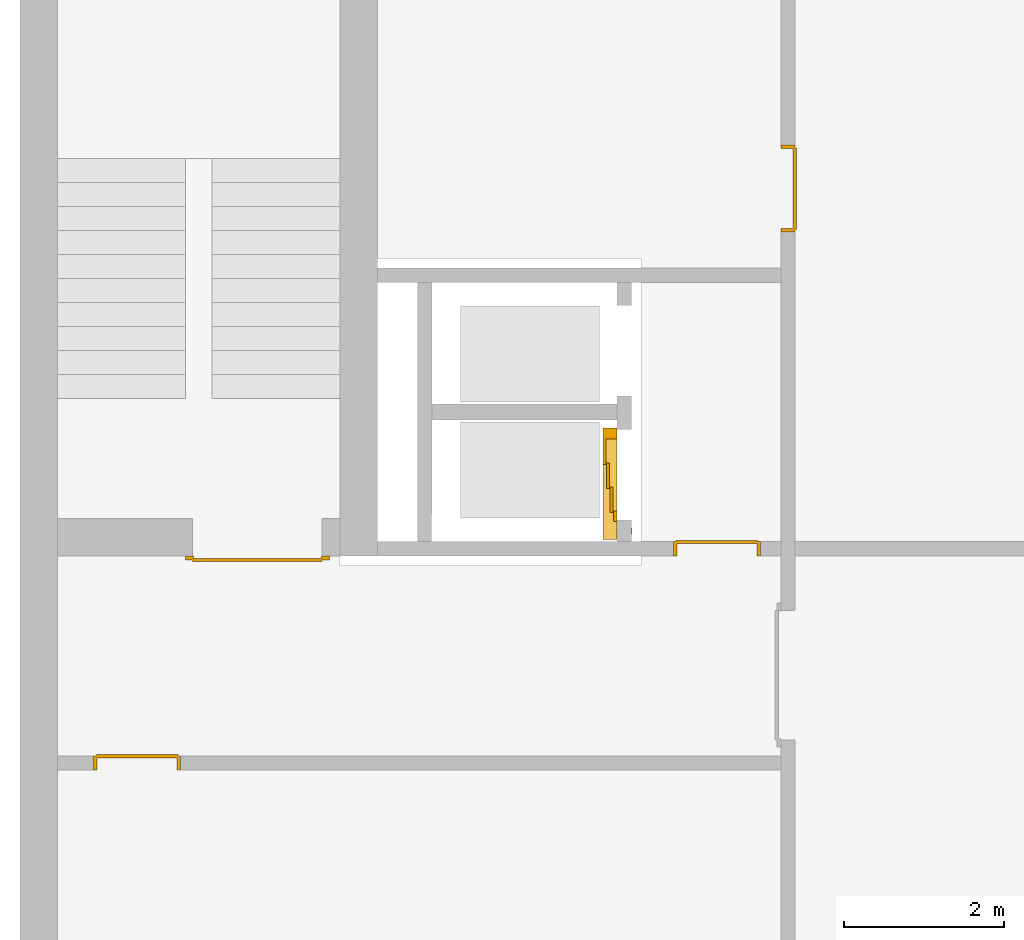
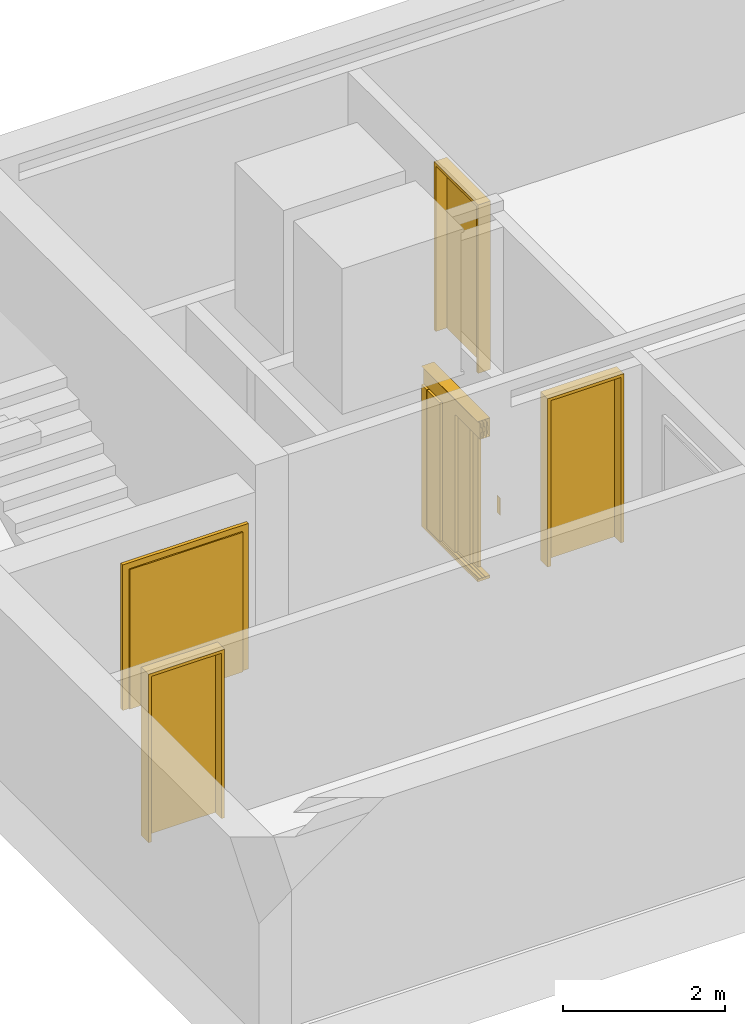
# One storey, part 4 of 5: 5 doors.
"""IFC4 building model written with IfcOpenShell, lengths in metres."""

from ifc_helpers import new_model, entity, si_unit, converted_unit, derived_unit, direction, frame, origin_with_axes, place, context, subcontext, project, spatial, polygons, source, transform, mapped, type_object, element, save


model = new_model("IFC4")

# Units and contexts
model_context = context("Model", 3, precision=1e-05, world=origin_with_axes(), true_north=direction((0.0, 1.0)))
body_context = subcontext(model_context, "Body", "Model", "MODEL_VIEW")
ifc_project = project(units=[si_unit("LENGTHUNIT", "METRE"), si_unit("AREAUNIT", "SQUARE_METRE"), si_unit("VOLUMEUNIT", "CUBIC_METRE"), converted_unit("PLANEANGLEUNIT", "DEGREE", entity("IfcPlaneAngleMeasure", 0.0174532925199433), si_unit("PLANEANGLEUNIT", "RADIAN"), dimensions=[0, 0, 0, 0, 0, 0, 0]), converted_unit("TIMEUNIT", "Year", entity("IfcTimeMeasure", 31557600.0), si_unit("TIMEUNIT", "SECOND"), dimensions=[0, 0, 1, 0, 0, 0, 0]), si_unit("MASSUNIT", "GRAM", prefix="KILO"), si_unit("THERMODYNAMICTEMPERATUREUNIT", "DEGREE_CELSIUS"), si_unit("LUMINOUSINTENSITYUNIT", "LUMEN"), si_unit("ENERGYUNIT", "JOULE", prefix="MEGA"), derived_unit("THERMALCONDUCTANCEUNIT", [(si_unit("POWERUNIT", "WATT"), 1), (si_unit("LENGTHUNIT", "METRE"), -1), (si_unit("THERMODYNAMICTEMPERATUREUNIT", "KELVIN"), -1)]), derived_unit("SPECIFICHEATCAPACITYUNIT", [(si_unit("ENERGYUNIT", "JOULE"), 1), (si_unit("MASSUNIT", "GRAM", prefix="KILO"), -1), (si_unit("THERMODYNAMICTEMPERATUREUNIT", "KELVIN"), -1)]), derived_unit("MASSDENSITYUNIT", [(si_unit("MASSUNIT", "GRAM", prefix="KILO"), 1), (si_unit("VOLUMEUNIT", "CUBIC_METRE"), -1)])], contexts=[model_context])

# Site, building, storey
site_placement = place(None, origin_with_axes())
site = spatial("IfcSite", under=ifc_project, at=site_placement, CompositionType="ELEMENT")
building_placement = place(None, origin_with_axes())
building = spatial("IfcBuilding", under=site, at=building_placement, CompositionType="ELEMENT")
storey_placement = place(None, frame((0.0, 0.0, -3.0), z_axis=(0.0, 0.0, 1.0), x_axis=(1.0, 0.0, 0.0)))
storey = spatial("IfcBuildingStorey", under=building, at=storey_placement, Name="UG", CompositionType="ELEMENT", Elevation=-3.0)

# Doors
door_type_1 = type_object("IfcDoorType", Name="27", OperationType="SINGLE_SWING_LEFT", PredefinedType="DOOR")
door_1_placement = place(None, frame((24.953, 4.55499994546755, -3.0), z_axis=(0.0, 0.0, 1.0), x_axis=(1.0, 0.0, 0.0)))
element("IfcDoor", 1, at=door_1_placement, inside=storey, type_object=door_type_1, OverallHeight=2.545, OverallWidth=1.09, context=body_context, shape_type="Tessellation", body=[
    polygons([(-0.0449999999999982, -0.179999999999999, 0.0), (-0.0449999999999982, -0.179999999999999, 2.545), (-0.0449999999999982, -0.0249999999999995, 2.545), (-0.0449999999999982, -0.0249999999999986, 0.0), (0.0, -0.179999999999999, 0.0), (0.0, -0.179999999999999, 2.5), (0.444900000000001, -0.179999999999999, 2.5), (0.4999, -0.179999999999999, 2.5), (1.0, -0.18, 2.5), (1.0, -0.179999999999999, 0.0), (1.045, -0.179999999999999, 0.0), (1.045, -0.18, 2.545), (1.045, -0.0249999999999995, 2.545), (1.045, -0.0249999999999995, 0.0), (1.0, -0.0249999999999995, 0.0), (1.0, -0.0249999999999995, 2.5), (0.4999, -0.0249999999999995, 2.5), (0.444900000000001, -0.0249999999999995, 2.5), (0.0, -0.0249999999999995, 2.5), (0.0, -0.0249999999999986, 0.0)], [[[1, 2, 3, 4]], [[1, 5, 6, 7, 8, 9, 10, 11, 12, 2]], [[2, 12, 13, 3]], [[4, 3, 13, 14, 15, 16, 17, 18, 19, 20]], [[5, 1, 4, 20]], [[6, 5, 20, 19]], [[7, 6, 19, 18]], [[8, 7, 18, 17]], [[9, 8, 17, 16]], [[10, 9, 16, 15]], [[11, 10, 15, 14]], [[12, 11, 14, 13]]], closed=True),
    polygons([(-0.0449999999999982, -0.0249999999999986, 0.0), (-0.0449999999999982, -0.0249999999999995, 2.545), (-0.0449999999999982, 0.0, 2.545), (-0.0449999999999982, 0.0, 0.0), (-0.0100000000000016, -0.0249999999999986, 0.0), (-0.0100000000000016, -0.0249999999999995, 2.51), (0.454899999999999, -0.0249999999999995, 2.51), (0.489899999999999, -0.0249999999999995, 2.51), (1.01, -0.0249999999999995, 2.51), (1.01, -0.0249999999999995, 0.0), (1.045, -0.0249999999999995, 0.0), (1.045, -0.0249999999999995, 2.545), (1.045, 0.0, 2.545), (1.045, 0.0, 0.0), (1.01, 0.0, 0.0), (1.01, 0.0, 2.51), (0.489899999999999, 0.0, 2.51), (0.454899999999999, 0.0, 2.51), (-0.0100000000000016, 0.0, 2.51), (-0.0100000000000016, 0.0, 0.0)], [[[1, 2, 3, 4]], [[1, 5, 6, 7, 8, 9, 10, 11, 12, 2]], [[2, 12, 13, 3]], [[4, 3, 13, 14, 15, 16, 17, 18, 19, 20]], [[5, 1, 4, 20]], [[6, 5, 20, 19]], [[7, 6, 19, 18]], [[8, 7, 18, 17]], [[9, 8, 17, 16]], [[10, 9, 16, 15]], [[11, 10, 15, 14]], [[12, 11, 14, 13]]], closed=True),
    polygons([(-0.0100000000000016, 0.0150000000000015, 0.0), (-0.0100000000000016, 0.0150000000000006, 2.51), (1.01, 0.0150000000000006, 2.51), (1.01, 0.0150000000000006, 0.0), (-0.0100000000000016, -0.0249999999999986, 0.0), (-0.0100000000000016, -0.0249999999999995, 2.51), (1.01, -0.0249999999999995, 2.51), (1.01, -0.0249999999999995, 0.0)], [[[1, 2, 3, 4]], [[1, 5, 6, 2]], [[2, 6, 7, 3]], [[3, 7, 8, 4]], [[4, 8, 5, 1]], [[8, 7, 6, 5]]], closed=True),
])
door_2_placement = place(None, frame((33.505, 12.1499999454676, -3.0), z_axis=(0.0, 0.0, 1.0), x_axis=(0.0, -1.0, 0.0)))
element("IfcDoor", 2, at=door_2_placement, inside=storey, type_object=door_type_1, OverallHeight=2.545, OverallWidth=1.09, context=body_context, shape_type="Tessellation", body=[
    polygons([(-0.0449999999999999, 0.0, 0.0), (-0.0449999999999999, 0.0, 2.545), (-0.0449999999999999, 0.155000000000001, 2.545), (-0.0449999999999999, 0.155000000000001, 0.0), (0.0, 0.0, 0.0), (0.0, 0.0, 2.5), (0.444900000000001, 0.0, 2.5), (0.4999, 0.0, 2.5), (1.0, 0.0, 2.5), (1.0, 0.0, 0.0), (1.045, 0.0, 0.0), (1.045, 0.0, 2.545), (1.045, 0.155000000000001, 2.545), (1.045, 0.155000000000001, 0.0), (1.0, 0.155000000000001, 0.0), (1.0, 0.155000000000001, 2.5), (0.4999, 0.155000000000001, 2.5), (0.444900000000001, 0.155000000000001, 2.5), (0.0, 0.155000000000001, 2.5), (0.0, 0.155000000000001, 0.0)], [[[1, 2, 3, 4]], [[1, 5, 6, 7, 8, 9, 10, 11, 12, 2]], [[2, 12, 13, 3]], [[4, 3, 13, 14, 15, 16, 17, 18, 19, 20]], [[5, 1, 4, 20]], [[6, 5, 20, 19]], [[7, 6, 19, 18]], [[8, 7, 18, 17]], [[9, 8, 17, 16]], [[10, 9, 16, 15]], [[11, 10, 15, 14]], [[12, 11, 14, 13]]], closed=True),
    polygons([(-0.0449999999999999, 0.155000000000001, 0.0), (-0.0449999999999999, 0.155000000000001, 2.545), (-0.0449999999999999, 0.18, 2.545), (-0.0449999999999999, 0.18, 0.0), (-0.00999999999999979, 0.155000000000001, 0.0), (-0.00999999999999979, 0.155000000000001, 2.51), (0.4549, 0.155000000000001, 2.51), (0.4899, 0.155000000000001, 2.51), (1.01, 0.155000000000001, 2.51), (1.01, 0.155000000000001, 0.0), (1.045, 0.155000000000001, 0.0), (1.045, 0.155000000000001, 2.545), (1.045, 0.18, 2.545), (1.045, 0.18, 0.0), (1.01, 0.18, 0.0), (1.01, 0.18, 2.51), (0.4899, 0.18, 2.51), (0.4549, 0.18, 2.51), (-0.00999999999999979, 0.18, 2.51), (-0.00999999999999979, 0.18, 0.0)], [[[1, 2, 3, 4]], [[1, 5, 6, 7, 8, 9, 10, 11, 12, 2]], [[2, 12, 13, 3]], [[4, 3, 13, 14, 15, 16, 17, 18, 19, 20]], [[5, 1, 4, 20]], [[6, 5, 20, 19]], [[7, 6, 19, 18]], [[8, 7, 18, 17]], [[9, 8, 17, 16]], [[10, 9, 16, 15]], [[11, 10, 15, 14]], [[12, 11, 14, 13]]], closed=True),
    polygons([(-0.00999999999999979, 0.195, 0.0), (-0.00999999999999979, 0.195, 2.51), (1.01, 0.195, 2.51), (1.01, 0.195, 0.0), (-0.00999999999999979, 0.155000000000001, 0.0), (-0.00999999999999979, 0.155000000000001, 2.51), (1.01, 0.155000000000001, 2.51), (1.01, 0.155000000000001, 0.0)], [[[1, 2, 3, 4]], [[1, 5, 6, 2]], [[2, 6, 7, 3]], [[3, 7, 8, 4]], [[4, 8, 5, 1]], [[8, 7, 6, 5]]], closed=True),
])
door_type_2 = type_object("IfcDoorType", Name="27", OperationType="SINGLE_SWING_RIGHT", PredefinedType="DOOR")
door_3_placement = place(None, frame((32.205, 7.05499994546755, -3.0), z_axis=(0.0, 0.0, 1.0), x_axis=(1.0, 0.0, 0.0)))
element("IfcDoor", 3, at=door_3_placement, inside=storey, type_object=door_type_2, OverallHeight=2.545, OverallWidth=1.09, context=body_context, shape_type="Tessellation", body=[
    polygons([(1.045, 0.0, 0.0), (1.045, 0.154999999999999, 0.0), (1.045, 0.155, 2.545), (1.045, 0.0, 2.545), (1.0, 0.0, 0.0), (1.0, 0.154999999999999, 0.0), (1.0, 0.155, 2.5), (0.555100000000003, 0.155, 2.5), (0.500100000000003, 0.155, 2.5), (0.0, 0.155, 2.5), (0.0, 0.154999999999999, 0.0), (-0.0450000000000017, 0.154999999999999, 0.0), (-0.0450000000000017, 0.155, 2.545), (-0.0450000000000017, 0.0, 2.545), (-0.0450000000000017, 0.0, 0.0), (0.0, 0.0, 0.0), (0.0, 0.0, 2.5), (0.500100000000003, 0.0, 2.5), (0.555100000000003, 0.0, 2.5), (1.0, 0.0, 2.5)], [[[1, 2, 3, 4]], [[5, 6, 2, 1]], [[2, 6, 7, 8, 9, 10, 11, 12, 13, 3]], [[4, 3, 13, 14]], [[1, 4, 14, 15, 16, 17, 18, 19, 20, 5]], [[20, 7, 6, 5]], [[19, 8, 7, 20]], [[18, 9, 8, 19]], [[17, 10, 9, 18]], [[16, 11, 10, 17]], [[15, 12, 11, 16]], [[14, 13, 12, 15]]], closed=True),
    polygons([(1.045, 0.154999999999999, 0.0), (1.045, 0.18, 0.0), (1.045, 0.18, 2.545), (1.045, 0.155, 2.545), (1.01, 0.154999999999999, 0.0), (1.01, 0.18, 0.0), (1.01, 0.18, 2.51), (0.545099999999998, 0.18, 2.51), (0.510100000000001, 0.18, 2.51), (-0.00999999999999801, 0.18, 2.51), (-0.00999999999999801, 0.18, 0.0), (-0.0450000000000017, 0.18, 0.0), (-0.0450000000000017, 0.18, 2.545), (-0.0450000000000017, 0.155, 2.545), (-0.0450000000000017, 0.154999999999999, 0.0), (-0.00999999999999801, 0.154999999999999, 0.0), (-0.00999999999999801, 0.155, 2.51), (0.510100000000001, 0.155, 2.51), (0.545099999999998, 0.155, 2.51), (1.01, 0.155, 2.51)], [[[1, 2, 3, 4]], [[5, 6, 2, 1]], [[2, 6, 7, 8, 9, 10, 11, 12, 13, 3]], [[4, 3, 13, 14]], [[1, 4, 14, 15, 16, 17, 18, 19, 20, 5]], [[20, 7, 6, 5]], [[19, 8, 7, 20]], [[18, 9, 8, 19]], [[17, 10, 9, 18]], [[16, 11, 10, 17]], [[15, 12, 11, 16]], [[14, 13, 12, 15]]], closed=True),
    polygons([(1.01, 0.194999999999999, 0.0), (-0.00999999999999801, 0.194999999999999, 0.0), (-0.00999999999999801, 0.195, 2.51), (1.01, 0.195, 2.51), (1.01, 0.154999999999999, 0.0), (-0.00999999999999801, 0.154999999999999, 0.0), (-0.00999999999999801, 0.155, 2.51), (1.01, 0.155, 2.51)], [[[1, 2, 3, 4]], [[2, 1, 5, 6]], [[3, 2, 6, 7]], [[4, 3, 7, 8]], [[1, 4, 8, 5]], [[6, 5, 8, 7]]], closed=True),
])
door_type_3 = type_object("IfcDoorType", OperationType="DOUBLE_DOOR_SINGLE_SWING", PredefinedType="DOOR")
shared_shape_1 = source(origin_with_axes(), body_context, "Body", "Tessellation", [
    polygons([(-0.9, 0.0, 0.0), (-0.9, 0.0, 2.2), (-0.9, 0.03, 2.2), (-0.9, 0.03, 0.0), (-0.8, 0.0, 0.0), (-0.8, 0.0, 2.1), (-0.1101, 0.0, 2.1), (-0.0001, 0.0, 2.1), (0.8, 0.0, 2.1), (0.8, 0.0, 0.0), (0.9, 0.0, 0.0), (0.9, 0.0, 2.2), (0.9, 0.03, 2.2), (0.9, 0.03, 0.0), (0.8, 0.03, 0.0), (0.8, 0.03, 2.1), (-0.0001, 0.03, 2.1), (-0.1101, 0.03, 2.1), (-0.8, 0.03, 2.1), (-0.8, 0.03, 0.0)], [[[1, 2, 3, 4]], [[1, 5, 6, 7, 8, 9, 10, 11, 12, 2]], [[2, 12, 13, 3]], [[4, 3, 13, 14, 15, 16, 17, 18, 19, 20]], [[5, 1, 4, 20]], [[6, 5, 20, 19]], [[7, 6, 19, 18]], [[8, 7, 18, 17]], [[9, 8, 17, 16]], [[10, 9, 16, 15]], [[11, 10, 15, 14]], [[12, 11, 14, 13]]], closed=True),
    polygons([(-0.9, 0.03, 0.0), (-0.9, 0.03, 2.2), (-0.9, 0.05, 2.2), (-0.9, 0.05, 0.0), (-0.81, 0.03, 0.0), (-0.81, 0.03, 2.11), (-0.1001, 0.03, 2.11), (-0.0101, 0.03, 2.11), (0.81, 0.03, 2.11), (0.81, 0.03, 0.0), (0.9, 0.03, 0.0), (0.9, 0.03, 2.2), (0.9, 0.05, 2.2), (0.9, 0.05, 0.0), (0.81, 0.05, 0.0), (0.81, 0.05, 2.11), (-0.0101, 0.05, 2.11), (-0.1001, 0.05, 2.11), (-0.81, 0.05, 2.11), (-0.81, 0.05, 0.0)], [[[1, 2, 3, 4]], [[1, 5, 6, 7, 8, 9, 10, 11, 12, 2]], [[2, 12, 13, 3]], [[4, 3, 13, 14, 15, 16, 17, 18, 19, 20]], [[5, 1, 4, 20]], [[6, 5, 20, 19]], [[7, 6, 19, 18]], [[8, 7, 18, 17]], [[9, 8, 17, 16]], [[10, 9, 16, 15]], [[11, 10, 15, 14]], [[12, 11, 14, 13]]], closed=True),
    polygons([(-0.81, 0.07, 0.0), (-0.81, 0.07, 2.11), (-0.000499999999999945, 0.07, 2.11), (-0.000499999999999945, 0.07, 0.0), (-0.81, 0.03, 0.0), (-0.81, 0.03, 2.11), (-0.000499999999999945, 0.03, 2.11), (-0.000499999999999945, 0.03, 0.0)], [[[1, 2, 3, 4]], [[1, 5, 6, 2]], [[2, 6, 7, 3]], [[3, 7, 8, 4]], [[4, 8, 5, 1]], [[8, 7, 6, 5]]], closed=True),
    polygons([(0.81, 0.07, 0.0), (0.000499999999999945, 0.07, 0.0), (0.000499999999999945, 0.07, 2.11), (0.81, 0.07, 2.11), (0.81, 0.03, 0.0), (0.000499999999999945, 0.03, 0.0), (0.000499999999999945, 0.03, 2.11), (0.81, 0.03, 2.11)], [[[1, 2, 3, 4]], [[2, 1, 5, 6]], [[3, 2, 6, 7]], [[4, 3, 7, 8]], [[1, 4, 8, 5]], [[6, 5, 8, 7]]], closed=True),
])
door_4_placement = place(None, frame((27.758, 7.05499994546755, -3.0), z_axis=(0.0, 0.0, 1.0), x_axis=(-1.0, 0.0, 0.0)))
element("IfcDoor", 4, at=door_4_placement, inside=storey, type_object=door_type_3, OverallHeight=2.11, OverallWidth=1.62, context=body_context, shape_type="MappedRepresentation", body=[
    mapped(shared_shape_1, transform((0.800000000000001, 0.0, 0.0))),
])
door_type_4 = type_object("IfcDoorType", Name="27", OperationType="DOUBLE_DOOR_SLIDING", PredefinedType="DOOR")
shared_shape_2 = source(origin_with_axes(), body_context, "Body", "Tessellation", [
    polygons([(-0.808333333333334, 0.135, 2.1), (-0.808333333333334, 0.135, 2.138), (0.585, 0.135, 2.138), (0.585, 0.135, 2.1), (-0.808333333333334, 0.0, 2.1), (-0.808333333333334, 0.0, 2.38), (-0.808333333333334, 0.18, 2.38), (-0.808333333333334, 0.18, 2.377), (-0.808333333333334, 0.003, 2.377), (-0.808333333333334, 0.003, 2.103), (-0.808333333333334, 0.132, 2.103), (-0.808333333333334, 0.132, 2.138), (0.585, 0.132, 2.138), (0.585, 0.132, 2.103), (0.585, 0.00299999999999992, 2.103), (0.585, 0.00299999999999992, 2.377), (0.585, 0.18, 2.377), (0.585, 0.18, 2.38), (0.585, 0.0, 2.38), (0.585, 0.0, 2.1)], [[[1, 2, 3, 4]], [[1, 5, 6, 7, 8, 9, 10, 11, 12, 2]], [[2, 12, 13, 3]], [[4, 3, 13, 14, 15, 16, 17, 18, 19, 20]], [[5, 1, 4, 20]], [[6, 5, 20, 19]], [[7, 6, 19, 18]], [[8, 7, 18, 17]], [[9, 8, 17, 16]], [[10, 9, 16, 15]], [[11, 10, 15, 14]], [[12, 11, 14, 13]]], closed=True),
    polygons([(-0.808333333333334, 0.05, 2.103), (-0.808333333333334, 0.055, 2.103), (0.585, 0.0549999999999999, 2.103), (0.585, 0.0499999999999999, 2.103), (-0.808333333333334, 0.05, 2.34), (-0.808333333333334, 0.055, 2.34), (0.585, 0.0549999999999999, 2.34), (0.585, 0.0499999999999999, 2.34)], [[[1, 2, 3, 4]], [[1, 5, 6, 2]], [[2, 6, 7, 3]], [[4, 3, 7, 8]], [[5, 1, 4, 8]], [[6, 5, 8, 7]]], closed=True),
    polygons([(-0.808333333333334, 0.05, 2.33), (-0.808333333333334, 0.04, 2.33), (0.585, 0.0399999999999999, 2.33), (0.585, 0.0499999999999999, 2.33), (-0.808333333333334, 0.05, 2.27), (-0.808333333333334, 0.04, 2.27), (0.585, 0.0399999999999999, 2.27), (0.585, 0.0499999999999999, 2.27)], [[[1, 2, 3, 4]], [[1, 5, 6, 2]], [[2, 6, 7, 3]], [[4, 3, 7, 8]], [[5, 1, 4, 8]], [[6, 5, 8, 7]]], closed=True),
    polygons([(-0.808333333333334, 0.05, 2.2), (-0.808333333333334, 0.04, 2.2), (0.585, 0.0399999999999999, 2.2), (0.585, 0.0499999999999999, 2.2), (-0.808333333333334, 0.05, 2.16), (-0.808333333333334, 0.04, 2.16), (0.585, 0.0399999999999999, 2.16), (0.585, 0.0499999999999999, 2.16)], [[[1, 2, 3, 4]], [[1, 5, 6, 2]], [[2, 6, 7, 3]], [[4, 3, 7, 8]], [[5, 1, 4, 8]], [[6, 5, 8, 7]]], closed=True),
    polygons([(-0.808333333333334, 0.05, 2.27), (-0.808333333333334, 0.03, 2.27), (0.585, 0.0299999999999999, 2.27), (0.585, 0.0499999999999999, 2.27), (-0.808333333333334, 0.05, 2.2), (-0.808333333333334, 0.03, 2.2), (0.585, 0.0299999999999999, 2.2), (0.585, 0.0499999999999999, 2.2)], [[[1, 2, 3, 4]], [[1, 5, 6, 2]], [[2, 6, 7, 3]], [[4, 3, 7, 8]], [[5, 1, 4, 8]], [[6, 5, 8, 7]]], closed=True),
    polygons([(-0.808333333333334, 0.095, 2.103), (-0.808333333333334, 0.1, 2.103), (0.585, 0.0999999999999999, 2.103), (0.585, 0.0949999999999999, 2.103), (-0.808333333333334, 0.095, 2.34), (-0.808333333333334, 0.1, 2.34), (0.585, 0.0999999999999999, 2.34), (0.585, 0.0949999999999999, 2.34)], [[[1, 2, 3, 4]], [[1, 5, 6, 2]], [[2, 6, 7, 3]], [[4, 3, 7, 8]], [[5, 1, 4, 8]], [[6, 5, 8, 7]]], closed=True),
    polygons([(-0.808333333333334, 0.095, 2.33), (-0.808333333333334, 0.085, 2.33), (0.585, 0.0849999999999999, 2.33), (0.585, 0.0949999999999999, 2.33), (-0.808333333333334, 0.095, 2.27), (-0.808333333333334, 0.085, 2.27), (0.585, 0.0849999999999999, 2.27), (0.585, 0.0949999999999999, 2.27)], [[[1, 2, 3, 4]], [[1, 5, 6, 2]], [[2, 6, 7, 3]], [[4, 3, 7, 8]], [[5, 1, 4, 8]], [[6, 5, 8, 7]]], closed=True),
    polygons([(-0.808333333333334, 0.095, 2.2), (-0.808333333333334, 0.085, 2.2), (0.585, 0.0849999999999999, 2.2), (0.585, 0.0949999999999999, 2.2), (-0.808333333333334, 0.095, 2.16), (-0.808333333333334, 0.085, 2.16), (0.585, 0.0849999999999999, 2.16), (0.585, 0.0949999999999999, 2.16)], [[[1, 2, 3, 4]], [[1, 5, 6, 2]], [[2, 6, 7, 3]], [[4, 3, 7, 8]], [[5, 1, 4, 8]], [[6, 5, 8, 7]]], closed=True),
    polygons([(-0.808333333333334, 0.095, 2.27), (-0.808333333333334, 0.075, 2.27), (0.585, 0.0749999999999999, 2.27), (0.585, 0.0949999999999999, 2.27), (-0.808333333333334, 0.095, 2.2), (-0.808333333333334, 0.075, 2.2), (0.585, 0.0749999999999999, 2.2), (0.585, 0.0949999999999999, 2.2)], [[[1, 2, 3, 4]], [[1, 5, 6, 2]], [[2, 6, 7, 3]], [[4, 3, 7, 8]], [[5, 1, 4, 8]], [[6, 5, 8, 7]]], closed=True),
    polygons([(-0.808333333333334, 0.14, 2.103), (-0.808333333333334, 0.145, 2.103), (0.585, 0.145, 2.103), (0.585, 0.14, 2.103), (-0.808333333333334, 0.14, 2.34), (-0.808333333333334, 0.145, 2.34), (0.585, 0.145, 2.34), (0.585, 0.14, 2.34)], [[[1, 2, 3, 4]], [[1, 5, 6, 2]], [[2, 6, 7, 3]], [[4, 3, 7, 8]], [[5, 1, 4, 8]], [[6, 5, 8, 7]]], closed=True),
    polygons([(-0.808333333333334, 0.14, 2.33), (-0.808333333333334, 0.13, 2.33), (0.585, 0.13, 2.33), (0.585, 0.14, 2.33), (-0.808333333333334, 0.14, 2.27), (-0.808333333333334, 0.13, 2.27), (0.585, 0.13, 2.27), (0.585, 0.14, 2.27)], [[[1, 2, 3, 4]], [[1, 5, 6, 2]], [[2, 6, 7, 3]], [[4, 3, 7, 8]], [[5, 1, 4, 8]], [[6, 5, 8, 7]]], closed=True),
    polygons([(-0.808333333333334, 0.14, 2.2), (-0.808333333333334, 0.13, 2.2), (0.585, 0.13, 2.2), (0.585, 0.14, 2.2), (-0.808333333333334, 0.14, 2.16), (-0.808333333333334, 0.13, 2.16), (0.585, 0.13, 2.16), (0.585, 0.14, 2.16)], [[[1, 2, 3, 4]], [[1, 5, 6, 2]], [[2, 6, 7, 3]], [[4, 3, 7, 8]], [[5, 1, 4, 8]], [[6, 5, 8, 7]]], closed=True),
    polygons([(-0.808333333333334, 0.14, 2.27), (-0.808333333333334, 0.12, 2.27), (0.585, 0.12, 2.27), (0.585, 0.14, 2.27), (-0.808333333333334, 0.14, 2.2), (-0.808333333333334, 0.12, 2.2), (0.585, 0.12, 2.2), (0.585, 0.14, 2.2)], [[[1, 2, 3, 4]], [[1, 5, 6, 2]], [[2, 6, 7, 3]], [[4, 3, 7, 8]], [[5, 1, 4, 8]], [[6, 5, 8, 7]]], closed=True),
    polygons([(-0.808333333333334, 0.0, 0.0), (-0.808333333333334, 0.0, -0.04), (0.585, 0.0, -0.04), (0.585, 0.0, 0.0), (-0.808333333333334, 0.065, 0.0), (-0.808333333333334, 0.065, -0.01), (-0.808333333333334, 0.075, -0.01), (-0.808333333333334, 0.075, 0.0), (-0.808333333333334, 0.11, 0.0), (-0.808333333333334, 0.11, -0.01), (-0.808333333333334, 0.12, -0.01), (-0.808333333333334, 0.12, 0.0), (-0.808333333333334, 0.155, 0.0), (-0.808333333333334, 0.155, -0.01), (-0.808333333333334, 0.165, -0.01), (-0.808333333333334, 0.165, 0.0), (-0.808333333333334, 0.18, 0.0), (-0.808333333333334, 0.18, -0.04), (0.585, 0.18, -0.04), (0.585, 0.18, 0.0), (0.585, 0.165, 0.0), (0.585, 0.165, -0.01), (0.585, 0.155, -0.01), (0.585, 0.155, 0.0), (0.585, 0.12, 0.0), (0.585, 0.12, -0.01), (0.585, 0.11, -0.01), (0.585, 0.11, 0.0), (0.585, 0.0749999999999999, 0.0), (0.585, 0.0749999999999999, -0.01), (0.585, 0.0649999999999999, -0.01), (0.585, 0.0649999999999999, 0.0)], [[[1, 2, 3, 4]], [[1, 5, 6, 7, 8, 9, 10, 11, 12, 13, 14, 15, 16, 17, 18, 2]], [[2, 18, 19, 3]], [[4, 3, 19, 20, 21, 22, 23, 24, 25, 26, 27, 28, 29, 30, 31, 32]], [[5, 1, 4, 32]], [[6, 5, 32, 31]], [[7, 6, 31, 30]], [[8, 7, 30, 29]], [[9, 8, 29, 28]], [[10, 9, 28, 27]], [[11, 10, 27, 26]], [[12, 11, 26, 25]], [[13, 12, 25, 24]], [[14, 13, 24, 23]], [[15, 14, 23, 22]], [[16, 15, 22, 21]], [[17, 16, 21, 20]], [[18, 17, 20, 19]]], closed=True),
    polygons([(-0.45, 0.0, 0.0), (-0.45, 0.045, 0.0), (-0.45, 0.0449999999999999, 2.1), (-0.45, 0.0, 2.1), (-0.585, 0.0, 0.0), (-0.585, 0.045, 0.0), (-0.585, 0.0449999999999999, 2.1), (-0.585, 0.0, 2.1)], [[[1, 2, 3, 4]], [[1, 5, 6, 2]], [[2, 6, 7, 3]], [[4, 3, 7, 8]], [[5, 1, 4, 8]], [[6, 5, 8, 7]]], closed=True),
    polygons([(0.585, 0.0, 0.0), (0.585, 0.18, 0.0), (0.585, 0.18, 2.1), (0.585, 0.0, 2.1), (0.45, 0.0, 0.0), (0.45, 0.18, 0.0), (0.45, 0.18, 2.1), (0.45, 0.0, 2.1)], [[[1, 2, 3, 4]], [[1, 5, 6, 2]], [[2, 6, 7, 3]], [[4, 3, 7, 8]], [[5, 1, 4, 8]], [[6, 5, 8, 7]]], closed=True),
    polygons([(-0.745, -0.18, 0.8), (-0.665, -0.18, 0.8), (-0.665, -0.183, 0.8), (-0.745, -0.183, 0.8), (-0.745, -0.18, 1.06), (-0.665, -0.18, 1.06), (-0.735, -0.18, 1.03), (-0.735, -0.18, 0.94), (-0.675, -0.18, 0.94), (-0.675, -0.18, 1.03), (-0.715, -0.18, 0.84), (-0.695, -0.18, 0.84), (-0.695, -0.18, 0.86), (-0.715, -0.18, 0.86), (-0.715, -0.18, 0.88), (-0.695, -0.18, 0.88), (-0.695, -0.18, 0.9), (-0.715, -0.18, 0.9), (-0.665, -0.183, 1.06), (-0.745, -0.183, 1.06), (-0.735, -0.183, 1.03), (-0.675, -0.183, 1.03), (-0.675, -0.183, 0.94), (-0.735, -0.183, 0.94), (-0.715, -0.183, 0.84), (-0.715, -0.183, 0.86), (-0.695, -0.183, 0.86), (-0.695, -0.183, 0.84), (-0.715, -0.183, 0.88), (-0.715, -0.183, 0.9), (-0.695, -0.183, 0.9), (-0.695, -0.183, 0.88)], [[[1, 2, 3, 4]], [[1, 5, 6, 2], [7, 8, 9, 10], [11, 12, 13, 14], [15, 16, 17, 18]], [[2, 6, 19, 3]], [[4, 3, 19, 20], [21, 22, 23, 24], [25, 26, 27, 28], [29, 30, 31, 32]], [[5, 1, 4, 20]], [[6, 5, 20, 19]], [[8, 7, 21, 24]], [[9, 8, 24, 23]], [[10, 9, 23, 22]], [[7, 10, 22, 21]], [[12, 11, 25, 28]], [[13, 12, 28, 27]], [[14, 13, 27, 26]], [[11, 14, 26, 25]], [[16, 15, 29, 32]], [[17, 16, 32, 31]], [[18, 17, 31, 30]], [[15, 18, 30, 29]]], closed=True),
    polygons([(-0.735, -0.18, 0.94), (-0.675, -0.18, 0.94), (-0.675, -0.1825, 0.94), (-0.735, -0.1825, 0.94), (-0.735, -0.18, 1.03), (-0.675, -0.18, 1.03), (-0.675, -0.1825, 1.03), (-0.735, -0.1825, 1.03)], [[[1, 2, 3, 4]], [[1, 5, 6, 2]], [[2, 6, 7, 3]], [[4, 3, 7, 8]], [[5, 1, 4, 8]], [[6, 5, 8, 7]]], closed=True),
    polygons([(-0.721, -0.183, 1.005), (-0.715, -0.183, 1.021), (-0.709, -0.183, 1.005)], [[[1, 2, 3]]], closed=False),
    polygons([(-0.695, -0.183, 1.005), (-0.701, -0.183, 1.021), (-0.689, -0.183, 1.021)], [[[1, 2, 3]]], closed=False),
    polygons([(-0.707727272727273, -0.1835, 0.982), (-0.707727272727273, -0.1835, 0.971636363636364), (-0.709090909090909, -0.1835, 0.970272727272727), (-0.710454545454546, -0.1835, 0.971636363636364), (-0.710454545454546, -0.1835, 0.982), (-0.709090909090909, -0.1835, 0.983363636363636)], [[[1, 2, 3, 4, 5, 6]]], closed=False),
    polygons([(-0.707727272727273, -0.1835, 0.968363636363636), (-0.707727272727273, -0.1835, 0.958), (-0.709090909090909, -0.1835, 0.956636363636364), (-0.710454545454546, -0.1835, 0.958), (-0.710454545454546, -0.1835, 0.968363636363636), (-0.709090909090909, -0.1835, 0.969727272727273)], [[[1, 2, 3, 4, 5, 6]]], closed=False),
    polygons([(-0.688909090909091, -0.1835, 0.982272727272727), (-0.699272727272727, -0.1835, 0.982272727272727), (-0.700636363636364, -0.1835, 0.983636363636364), (-0.699272727272727, -0.1835, 0.985), (-0.688909090909091, -0.1835, 0.985), (-0.687545454545455, -0.1835, 0.983636363636364)], [[[1, 2, 3, 4, 5, 6]]], closed=False),
    polygons([(-0.685909090909091, -0.1835, 0.982), (-0.685909090909091, -0.1835, 0.971636363636364), (-0.687272727272727, -0.1835, 0.970272727272727), (-0.688636363636364, -0.1835, 0.971636363636364), (-0.688636363636364, -0.1835, 0.982), (-0.687272727272727, -0.1835, 0.983363636363636)], [[[1, 2, 3, 4, 5, 6]]], closed=False),
    polygons([(-0.688909090909091, -0.1835, 0.968636363636364), (-0.699272727272727, -0.1835, 0.968636363636364), (-0.700636363636364, -0.1835, 0.97), (-0.699272727272727, -0.1835, 0.971363636363636), (-0.688909090909091, -0.1835, 0.971363636363636), (-0.687545454545455, -0.1835, 0.97)], [[[1, 2, 3, 4, 5, 6]]], closed=False),
    polygons([(-0.699545454545455, -0.1835, 0.968363636363636), (-0.699545454545455, -0.1835, 0.958), (-0.700909090909091, -0.1835, 0.956636363636364), (-0.702272727272727, -0.1835, 0.958), (-0.702272727272727, -0.1835, 0.968363636363636), (-0.700909090909091, -0.1835, 0.969727272727273)], [[[1, 2, 3, 4, 5, 6]]], closed=False),
    polygons([(-0.688909090909091, -0.1835, 0.955), (-0.699272727272727, -0.1835, 0.955), (-0.700636363636364, -0.1835, 0.956363636363636), (-0.699272727272727, -0.1835, 0.957727272727273), (-0.688909090909091, -0.1835, 0.957727272727273), (-0.687545454545455, -0.1835, 0.956363636363636)], [[[1, 2, 3, 4, 5, 6]]], closed=False),
    polygons([(-0.695, -0.18, 0.84), (-0.715, -0.18, 0.84), (-0.715, -0.18, 0.86), (-0.695, -0.18, 0.86), (-0.694999999905229, -0.1815, 0.839999999610484), (-0.715000000389516, -0.1815, 0.839999999610484), (-0.715000000389516, -0.1815, 0.860000000094772), (-0.694999999905229, -0.1815, 0.860000000094772), (-0.696400000320971, -0.182900000415742, 0.841400000026226), (-0.713599999973774, -0.182900000415742, 0.841400000026226), (-0.713599999973774, -0.182900000415742, 0.858599999679029), (-0.696400000320971, -0.182900000415742, 0.858599999679029)], [[[1, 2, 3, 4]], [[2, 1, 5, 6]], [[3, 2, 6, 7]], [[4, 3, 7, 8]], [[1, 4, 8, 5]], [[6, 5, 9, 10]], [[7, 6, 10, 11]], [[8, 7, 11, 12]], [[5, 8, 12, 9]], [[11, 10, 9, 12]]], closed=True),
    polygons([(-0.7, -0.183, 0.855), (-0.705, -0.183, 0.844), (-0.71, -0.183, 0.855)], [[[1, 2, 3]]], closed=False),
    polygons([(-0.695, -0.18, 0.88), (-0.715, -0.18, 0.88), (-0.715, -0.18, 0.9), (-0.695, -0.18, 0.9), (-0.694999999905229, -0.1815, 0.879999999610484), (-0.715000000389516, -0.1815, 0.879999999610484), (-0.715000000389516, -0.1815, 0.900000000094772), (-0.694999999905229, -0.1815, 0.900000000094772), (-0.696400000320971, -0.182900000415742, 0.881400000026226), (-0.713599999973774, -0.182900000415742, 0.881400000026226), (-0.713599999973774, -0.182900000415742, 0.898599999679029), (-0.696400000320971, -0.182900000415742, 0.898599999679029)], [[[1, 2, 3, 4]], [[2, 1, 5, 6]], [[3, 2, 6, 7]], [[4, 3, 7, 8]], [[1, 4, 8, 5]], [[6, 5, 9, 10]], [[7, 6, 10, 11]], [[8, 7, 11, 12]], [[5, 8, 12, 9]], [[11, 10, 9, 12]]], closed=True),
    polygons([(-0.7, -0.183, 0.885), (-0.71, -0.183, 0.885), (-0.705, -0.183, 0.896)], [[[1, 2, 3]]], closed=False),
    polygons([(0.126666666666667, 0.14, 0.003), (0.126666666666667, 0.18, 0.003), (0.445, 0.18, 0.003), (0.445, 0.14, 0.003), (0.126666666666667, 0.14, 2.1), (0.126666666666667, 0.18, 2.1), (0.445, 0.18, 2.1), (0.445, 0.14, 2.1)], [[[1, 2, 3, 4]], [[5, 6, 2, 1]], [[2, 6, 7, 3]], [[4, 3, 7, 8]], [[1, 4, 8, 5]], [[8, 7, 6, 5]]], closed=True),
    polygons([(-0.171666666666667, 0.095, 0.003), (-0.171666666666667, 0.135, 0.003), (0.146666666666667, 0.135, 0.003), (0.146666666666667, 0.095, 0.003), (-0.171666666666667, 0.095, 2.1), (-0.171666666666667, 0.135, 2.1), (0.146666666666667, 0.135, 2.1), (0.146666666666667, 0.095, 2.1)], [[[1, 2, 3, 4]], [[5, 6, 2, 1]], [[2, 6, 7, 3]], [[4, 3, 7, 8]], [[1, 4, 8, 5]], [[8, 7, 6, 5]]], closed=True),
    polygons([(-0.47, 0.05, 0.003), (-0.47, 0.09, 0.003), (-0.151666666666667, 0.09, 0.003), (-0.151666666666667, 0.05, 0.003), (-0.47, 0.05, 2.1), (-0.47, 0.09, 2.1), (-0.151666666666667, 0.09, 2.1), (-0.151666666666667, 0.05, 2.1)], [[[1, 2, 3, 4]], [[5, 6, 2, 1]], [[2, 6, 7, 3]], [[4, 3, 7, 8]], [[1, 4, 8, 5]], [[8, 7, 6, 5]]], closed=True),
])
door_5_placement = place(None, frame((31.638, 7.61999994546756, -3.0), z_axis=(0.0, 0.0, 1.0), x_axis=(0.0, 1.0, 0.0)))
element("IfcDoor", 5, at=door_5_placement, inside=storey, type_object=door_type_4, OverallHeight=2.25, OverallWidth=1.13, context=body_context, shape_type="MappedRepresentation", body=[
    mapped(shared_shape_2, transform((0.450000000000001, 0.18, 0.0))),
])

save(model, "model.ifc")
